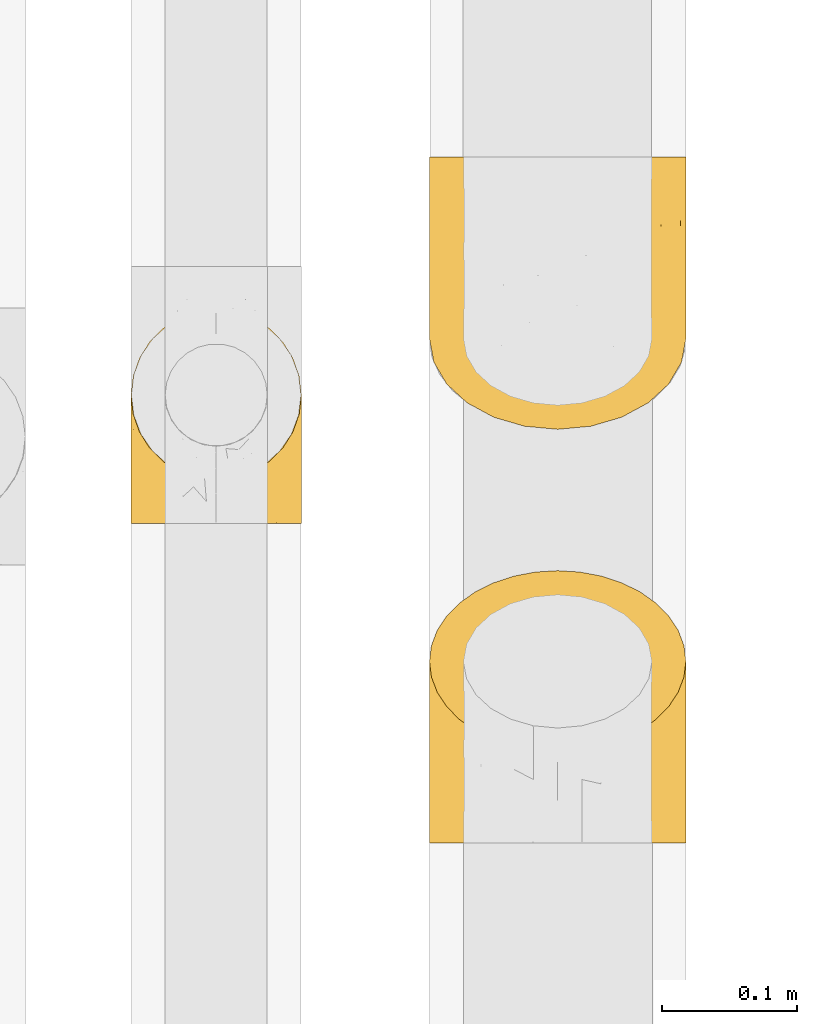
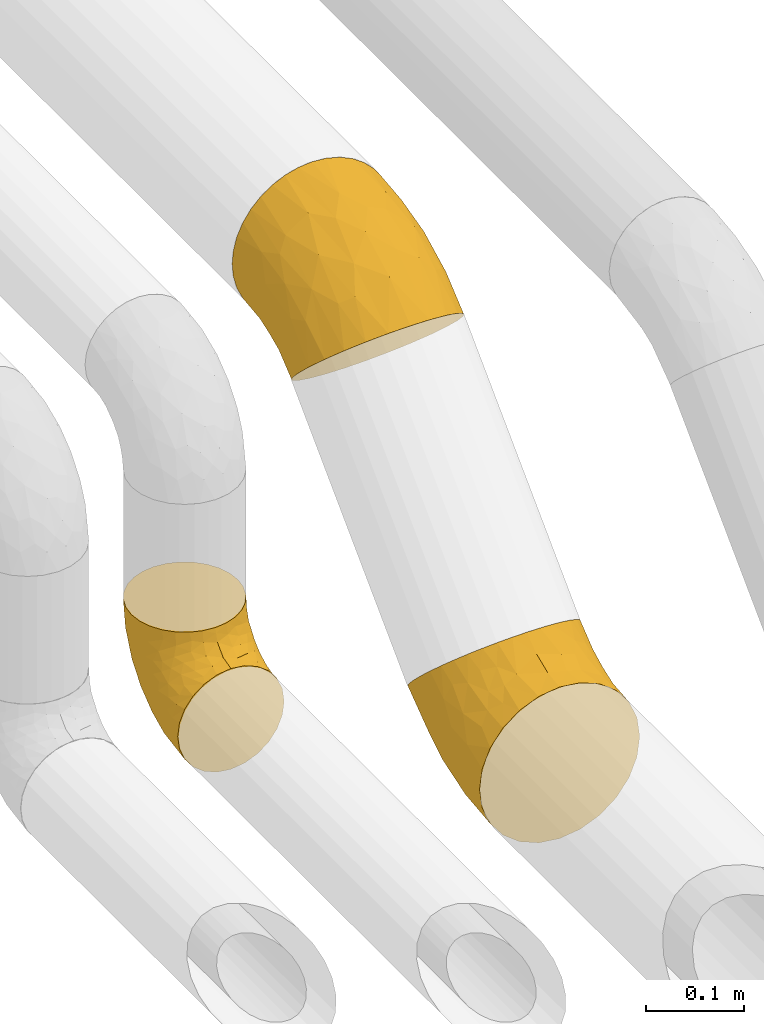
# One storey, part 103 of 827: 3 coverings.
"""IFC2X3 building model written with IfcOpenShell, lengths in millimetres."""

from ifc_helpers import new_model, entity, si_unit, converted_unit, derived_unit, direction, frame, origin, place, context, subcontext, project, spatial, faceted_brep, element, save


model = new_model("IFC2X3")

# Units and contexts
model_context = context("Model", 3, precision=0.01, world=origin(), true_north=direction((6.12303176911189e-17, 1.0)))
body_context = subcontext(model_context, "Body", "Model", "MODEL_VIEW")
ifc_project = project(units=[si_unit("LENGTHUNIT", "METRE", prefix="MILLI"), si_unit("AREAUNIT", "SQUARE_METRE"), si_unit("VOLUMEUNIT", "CUBIC_METRE"), converted_unit("PLANEANGLEUNIT", "DEGREE", entity("IfcRatioMeasure", 0.0174532925199433), si_unit("PLANEANGLEUNIT", "RADIAN"), dimensions=[0, 0, 0, 0, 0, 0, 0]), si_unit("MASSUNIT", "GRAM", prefix="KILO"), derived_unit("MASSDENSITYUNIT", [(si_unit("MASSUNIT", "GRAM", prefix="KILO"), 1), (si_unit("LENGTHUNIT", "METRE"), -3)]), derived_unit("MOMENTOFINERTIAUNIT", [(si_unit("LENGTHUNIT", "METRE"), 4)]), si_unit("TIMEUNIT", "SECOND"), si_unit("FREQUENCYUNIT", "HERTZ"), si_unit("THERMODYNAMICTEMPERATUREUNIT", "DEGREE_CELSIUS"), derived_unit("THERMALTRANSMITTANCEUNIT", [(si_unit("MASSUNIT", "GRAM", prefix="KILO"), 1), (si_unit("THERMODYNAMICTEMPERATUREUNIT", "KELVIN"), -1), (si_unit("TIMEUNIT", "SECOND"), -3)]), derived_unit("VOLUMETRICFLOWRATEUNIT", [(si_unit("LENGTHUNIT", "METRE"), 3), (si_unit("TIMEUNIT", "SECOND"), -1)]), derived_unit("MASSFLOWRATEUNIT", [(si_unit("MASSUNIT", "GRAM", prefix="KILO"), 1), (si_unit("TIMEUNIT", "SECOND"), -1)]), derived_unit("ROTATIONALFREQUENCYUNIT", [(si_unit("TIMEUNIT", "SECOND"), -1)]), si_unit("ELECTRICCURRENTUNIT", "AMPERE"), si_unit("ELECTRICVOLTAGEUNIT", "VOLT"), si_unit("POWERUNIT", "WATT"), si_unit("FORCEUNIT", "NEWTON", prefix="KILO"), si_unit("ILLUMINANCEUNIT", "LUX"), si_unit("LUMINOUSFLUXUNIT", "LUMEN"), si_unit("LUMINOUSINTENSITYUNIT", "CANDELA"), derived_unit("USERDEFINED", [(si_unit("MASSUNIT", "GRAM", prefix="KILO"), -1), (si_unit("LENGTHUNIT", "METRE"), -2), (si_unit("TIMEUNIT", "SECOND"), 3), (si_unit("LUMINOUSFLUXUNIT", "LUMEN"), 1)]), derived_unit("LINEARVELOCITYUNIT", [(si_unit("LENGTHUNIT", "METRE"), 1), (si_unit("TIMEUNIT", "SECOND"), -1)]), si_unit("PRESSUREUNIT", "PASCAL"), derived_unit("USERDEFINED", [(si_unit("LENGTHUNIT", "METRE"), -2), (si_unit("MASSUNIT", "GRAM", prefix="KILO"), 1), (si_unit("TIMEUNIT", "SECOND"), -2)]), derived_unit("LINEARFORCEUNIT", [(si_unit("MASSUNIT", "GRAM", prefix="KILO"), 1), (si_unit("LENGTHUNIT", "METRE"), 1), (si_unit("TIMEUNIT", "SECOND"), -2), (si_unit("LENGTHUNIT", "METRE"), -1)]), derived_unit("PLANARFORCEUNIT", [(si_unit("MASSUNIT", "GRAM", prefix="KILO"), 1), (si_unit("LENGTHUNIT", "METRE"), 1), (si_unit("TIMEUNIT", "SECOND"), -2), (si_unit("LENGTHUNIT", "METRE"), -2)])], contexts=[model_context])

# Site, building, storey
site_placement = place(None, origin())
site = spatial("IfcSite", under=ifc_project, at=site_placement, CompositionType="ELEMENT")
building_placement = place(site_placement, origin())
building = spatial("IfcBuilding", under=site, at=building_placement, CompositionType="ELEMENT")
storey_placement = place(building_placement, frame((0.0, 0.0, 28200.0)))
storey = spatial("IfcBuildingStorey", under=building, at=storey_placement, Name="08", CompositionType="ELEMENT", Elevation=28200.0)

# Coverings
covering_1_placement = place(storey_placement, frame((27023.89, 9323.51, 3003.55)))
element("IfcCovering", 1, at=covering_1_placement, inside=storey, Name=":ADSK_", ObjectType=":ADSK_", PredefinedType="INSULATION", context=body_context, shape_type="Brep", body=[
    faceted_brep([(128.89, 72.92, 215.12), (143.88, 77.86, 210.18), (157.42, 84.57, 203.47), (169.11, 92.84, 195.2), (178.59, 102.42, 185.62), (185.58, 113.01, 175.03), (189.86, 124.31, 163.73), (191.3, 135.95, 152.09), (189.85, 147.59, 140.45), (185.57, 158.89, 129.15), (178.58, 169.48, 118.56), (169.1, 179.06, 108.98), (157.41, 187.33, 100.71), (143.86, 194.03, 94.01), (128.88, 198.97, 89.07), (112.9, 202.0, 86.04), (96.45, 203.01, 85.03), (79.97, 202.0, 86.05), (64.0, 198.97, 89.07), (49.01, 194.03, 94.01), (35.47, 187.32, 100.72), (23.78, 179.05, 108.99), (14.3, 169.47, 118.57), (7.31, 158.88, 129.16), (3.03, 147.58, 140.46), (1.6, 135.95, 152.09), (3.04, 124.3, 163.74), (7.32, 113.0, 175.04), (14.31, 102.41, 185.63), (23.79, 92.83, 195.21), (35.48, 84.56, 203.48), (49.03, 77.86, 210.18), (64.02, 72.92, 215.12), (79.99, 69.89, 218.15), (96.45, 68.88, 219.16), (112.92, 69.9, 218.14), (71.9, 1.6, 188.06), (49.02, 1.6, 178.59), (29.38, 1.6, 163.51), (14.3, 1.6, 143.87), (4.83, 1.6, 120.99), (1.6, 1.6, 96.45), (4.83, 1.6, 71.9), (14.3, 1.6, 49.02), (29.38, 1.6, 29.38), (49.02, 1.6, 14.3), (71.9, 1.6, 4.83), (96.45, 1.6, 1.6), (120.99, 1.6, 4.83), (143.87, 1.6, 14.3), (163.51, 1.6, 29.38), (178.59, 1.6, 49.02), (188.06, 1.6, 71.9), (191.3, 1.6, 96.45), (188.06, 1.6, 120.99), (178.59, 1.6, 143.87), (163.51, 1.6, 163.51), (143.87, 1.6, 178.59), (120.99, 1.6, 188.06), (96.45, 1.6, 191.3), (148.44, 104.67, 37.62), (153.08, 49.39, 24.69), (137.11, 49.25, 14.9), (96.45, 57.17, 7.07), (123.57, 82.6, 17.49), (96.45, 110.6, 23.28), (96.45, 159.85, 49.6), (115.76, 135.24, 37.14), (166.75, 74.08, 43.35), (180.53, 91.1, 70.36), (181.55, 132.38, 94.96), (188.56, 99.69, 97.83), (186.72, 55.01, 73.95), (191.3, 38.66, 100.1), (180.27, 46.32, 56.37), (135.37, 150.71, 53.61), (162.08, 137.86, 66.8), (173.22, 121.84, 72.18), (191.3, 74.31, 110.91), (191.3, 107.15, 128.47), (186.39, 35.47, 130.17), (187.89, 65.55, 134.56), (179.11, 56.51, 153.88), (184.82, 86.32, 155.99), (174.14, 27.07, 153.27), (161.5, 25.9, 167.94), (168.52, 48.06, 166.8), (155.2, 45.81, 179.7), (140.11, 45.88, 190.36), (134.59, 24.1, 185.77), (123.18, 44.25, 197.11), (117.73, 23.39, 191.34), (166.26, 69.04, 180.25), (189.93, 89.08, 136.1), (189.1, 105.97, 152.6), (177.06, 75.48, 167.5), (150.17, 63.4, 193.25), (96.45, 49.17, 204.04), (96.45, 26.22, 194.54), (67.84, 39.7, 194.46), (54.37, 57.54, 197.6), (13.79, 56.5, 153.89), (8.08, 86.31, 156.0), (5.01, 65.54, 134.59), (2.97, 89.07, 136.11), (3.79, 105.96, 152.61), (52.05, 38.25, 186.79), (1.6, 38.66, 100.1), (6.5, 35.48, 130.17), (1.6, 74.31, 110.91), (18.75, 27.06, 153.26), (42.17, 23.58, 176.41), (28.93, 32.49, 167.0), (26.64, 69.03, 180.27), (39.77, 66.35, 192.69), (37.7, 45.81, 179.71), (16.37, 82.86, 173.47), (1.6, 107.15, 128.47), (4.39, 65.7, 83.48), (31.81, 101.99, 47.24), (35.92, 50.58, 28.01), (22.4, 52.35, 42.39), (73.84, 83.08, 16.35), (12.22, 48.87, 57.66), (5.54, 115.67, 101.77), (51.55, 67.49, 20.95), (12.22, 96.73, 73.07), (78.05, 135.48, 37.06), (58.02, 128.07, 40.32), (19.93, 135.83, 80.23), (41.41, 146.95, 62.18)], [[[0, 1, 2, 3, 4, 5, 6, 7, 8, 9, 10, 11, 12, 13, 14, 15, 16, 17, 18, 19, 20, 21, 22, 23, 24, 25, 26, 27, 28, 29, 30, 31, 32, 33, 34, 35]], [[36, 37, 38, 39, 40, 41, 42, 43, 44, 45, 46, 47, 48, 49, 50, 51, 52, 53, 54, 55, 56, 57, 58, 59]], [[60, 61, 62]], [[48, 47, 63]], [[64, 63, 65]], [[66, 67, 65]], [[51, 50, 68]], [[49, 61, 50]], [[69, 70, 71]], [[48, 63, 64]], [[72, 73, 52]], [[72, 74, 69]], [[60, 64, 75]], [[76, 77, 68]], [[72, 78, 73]], [[73, 53, 52]], [[72, 69, 71]], [[8, 71, 9]], [[60, 76, 68]], [[64, 65, 67]], [[67, 15, 14]], [[77, 10, 70]], [[76, 75, 12]], [[75, 13, 12]], [[68, 77, 69]], [[10, 77, 11]], [[14, 75, 67]], [[15, 66, 16]], [[68, 61, 60]], [[62, 61, 49]], [[48, 64, 62]], [[11, 77, 76]], [[79, 8, 7]], [[78, 71, 79]], [[61, 68, 50]], [[12, 11, 76]], [[71, 8, 79]], [[70, 10, 9]], [[15, 67, 66]], [[77, 70, 69]], [[60, 75, 76]], [[71, 70, 9]], [[64, 67, 75]], [[14, 13, 75]], [[48, 62, 49]], [[68, 69, 74]], [[60, 62, 64]], [[72, 71, 78]], [[74, 52, 51]], [[52, 74, 72]], [[68, 74, 51]], [[80, 78, 81]], [[54, 53, 73]], [[82, 81, 83]], [[80, 82, 84]], [[85, 86, 87]], [[55, 84, 56]], [[88, 89, 87]], [[54, 73, 80]], [[58, 57, 89]], [[90, 91, 89]], [[90, 0, 35]], [[2, 92, 3]], [[93, 78, 79]], [[59, 58, 91]], [[58, 89, 91]], [[78, 80, 73]], [[84, 85, 56]], [[94, 6, 5]], [[95, 4, 3]], [[86, 84, 82]], [[96, 2, 1]], [[95, 3, 92]], [[80, 84, 55]], [[93, 94, 83]], [[7, 6, 79]], [[86, 92, 87]], [[83, 95, 82]], [[85, 89, 57]], [[55, 54, 80]], [[34, 97, 35]], [[97, 90, 35]], [[93, 83, 81]], [[98, 90, 97]], [[0, 90, 88]], [[96, 1, 0]], [[85, 57, 56]], [[88, 90, 89]], [[82, 80, 81]], [[84, 86, 85]], [[83, 5, 4]], [[86, 82, 95]], [[85, 87, 89]], [[78, 93, 81]], [[94, 79, 6]], [[83, 94, 5]], [[79, 94, 93]], [[96, 88, 87]], [[88, 96, 0]], [[87, 92, 96]], [[2, 96, 92]], [[90, 98, 91]], [[59, 91, 98]], [[4, 95, 83]], [[86, 95, 92]], [[98, 99, 36]], [[100, 32, 31]], [[101, 102, 103]], [[104, 103, 102]], [[97, 99, 98]], [[59, 98, 36]], [[105, 27, 26]], [[99, 106, 36]], [[107, 40, 108]], [[109, 108, 103]], [[108, 39, 110]], [[41, 40, 107]], [[39, 108, 40]], [[106, 111, 37]], [[38, 111, 112]], [[39, 38, 110]], [[112, 113, 101]], [[31, 30, 114]], [[99, 97, 33]], [[38, 37, 111]], [[99, 33, 32]], [[102, 28, 27]], [[108, 109, 107]], [[113, 30, 29]], [[100, 114, 115]], [[30, 113, 114]], [[101, 110, 112]], [[32, 100, 99]], [[101, 113, 116]], [[102, 116, 28]], [[99, 100, 106]], [[108, 101, 103]], [[29, 28, 116]], [[106, 100, 115]], [[26, 25, 117]], [[104, 105, 117]], [[108, 110, 101]], [[104, 109, 103]], [[36, 106, 37]], [[33, 97, 34]], [[112, 111, 115]], [[111, 106, 115]], [[112, 115, 113]], [[38, 112, 110]], [[102, 27, 105]], [[109, 104, 117]], [[117, 105, 26]], [[102, 105, 104]], [[101, 116, 102]], [[29, 116, 113]], [[115, 114, 113]], [[31, 114, 100]], [[109, 118, 107]], [[119, 120, 121]], [[63, 122, 65]], [[123, 42, 118]], [[109, 117, 124]], [[41, 107, 42]], [[120, 119, 125]], [[126, 23, 22]], [[63, 47, 46]], [[42, 123, 43]], [[65, 127, 66]], [[122, 46, 125]], [[128, 127, 122]], [[44, 121, 120]], [[18, 17, 127]], [[125, 128, 122]], [[127, 128, 18]], [[121, 126, 119]], [[124, 117, 24]], [[45, 120, 125]], [[117, 25, 24]], [[43, 121, 44]], [[119, 128, 125]], [[118, 124, 126]], [[22, 129, 126]], [[124, 118, 109]], [[126, 124, 23]], [[129, 22, 21]], [[120, 45, 44]], [[21, 130, 129]], [[119, 130, 128]], [[128, 19, 18]], [[63, 46, 122]], [[65, 122, 127]], [[17, 16, 66]], [[130, 21, 20]], [[42, 107, 118]], [[127, 17, 66]], [[119, 126, 129]], [[19, 128, 130]], [[125, 46, 45]], [[24, 23, 124]], [[121, 43, 123]], [[123, 126, 121]], [[118, 126, 123]], [[129, 130, 119]], [[19, 130, 20]]]),
])
covering_2_placement = place(storey_placement, frame((27023.89, 9629.5, 3325.69)))
element("IfcCovering", 2, at=covering_2_placement, inside=storey, Name=":ADSK_", ObjectType=":ADSK_", PredefinedType="INSULATION", context=body_context, shape_type="Brep", body=[
    faceted_brep([(64.0, 203.01, 35.19), (49.01, 203.01, 42.18), (35.47, 203.01, 51.66), (23.78, 203.01, 63.35), (14.3, 203.01, 76.9), (7.31, 203.01, 91.88), (3.03, 203.01, 107.85), (1.6, 203.01, 124.31), (3.04, 203.01, 140.79), (7.32, 203.01, 156.76), (14.31, 203.01, 171.75), (23.79, 203.01, 185.29), (35.48, 203.01, 196.98), (49.03, 203.01, 206.46), (64.02, 203.01, 213.45), (79.99, 203.01, 217.73), (96.45, 203.01, 219.16), (112.92, 203.01, 217.72), (128.89, 203.01, 213.44), (143.88, 203.01, 206.45), (157.42, 203.01, 196.97), (169.11, 203.01, 185.28), (178.59, 203.01, 171.73), (185.58, 203.01, 156.74), (189.86, 203.01, 140.77), (191.3, 203.01, 124.31), (189.85, 203.01, 107.84), (185.57, 203.01, 91.87), (178.58, 203.01, 76.88), (169.1, 203.01, 63.34), (157.41, 203.01, 51.65), (143.86, 203.01, 42.17), (128.88, 203.01, 35.18), (112.9, 203.01, 30.9), (96.45, 203.01, 29.46), (79.97, 203.01, 30.91), (120.99, 133.45, 3.88), (143.87, 126.75, 10.58), (163.51, 116.09, 21.24), (178.59, 102.2, 35.13), (188.06, 86.02, 51.31), (191.3, 68.66, 68.66), (188.06, 51.31, 86.02), (178.59, 35.13, 102.2), (163.51, 21.24, 116.09), (143.87, 10.58, 126.75), (120.99, 3.88, 133.45), (96.45, 1.6, 135.73), (71.9, 3.88, 133.45), (49.02, 10.58, 126.75), (29.38, 21.24, 116.09), (14.3, 35.13, 102.2), (4.83, 51.31, 86.02), (1.6, 68.66, 68.66), (4.83, 86.02, 51.31), (14.3, 102.2, 35.13), (29.38, 116.09, 21.24), (49.02, 126.75, 10.58), (71.9, 133.45, 3.88), (96.45, 135.73, 1.6), (44.45, 99.95, 183.14), (39.81, 51.72, 153.2), (55.78, 44.71, 160.02), (96.45, 44.76, 171.16), (69.32, 70.11, 181.77), (96.45, 94.01, 197.48), (96.45, 147.44, 213.69), (77.13, 121.23, 205.1), (26.14, 82.38, 157.46), (12.36, 113.51, 150.4), (11.35, 160.09, 162.19), (4.33, 139.01, 137.05), (6.17, 90.53, 122.34), (1.6, 97.46, 92.29), (12.62, 71.96, 128.63), (57.52, 143.81, 204.4), (30.81, 144.05, 185.98), (19.67, 136.53, 170.85), (1.6, 130.3, 109.85), (1.6, 165.95, 120.66), (6.5, 116.46, 68.77), (5.0, 140.84, 86.93), (13.78, 148.1, 66.88), (8.07, 170.68, 86.47), (18.75, 126.85, 46.5), (31.39, 136.4, 35.3), (24.37, 151.27, 51.77), (37.69, 158.8, 41.06), (52.78, 166.39, 33.57), (58.3, 147.74, 21.41), (69.71, 170.01, 27.65), (75.16, 151.17, 16.97), (26.63, 175.62, 57.09), (2.96, 158.56, 102.48), (3.79, 182.17, 102.76), (15.83, 171.15, 70.66), (42.72, 180.81, 43.92), (96.45, 178.39, 26.22), (96.45, 155.44, 16.72), (125.05, 164.91, 26.3), (138.52, 179.75, 36.7), (179.1, 148.11, 66.87), (184.81, 170.68, 86.45), (187.88, 140.85, 86.91), (189.92, 158.57, 102.47), (189.1, 182.18, 102.74), (140.84, 158.47, 30.7), (191.3, 97.46, 92.29), (186.39, 116.47, 68.78), (191.3, 130.3, 109.85), (174.14, 126.85, 46.49), (150.72, 140.75, 27.67), (163.96, 140.4, 40.62), (166.25, 175.62, 57.08), (153.12, 182.51, 46.4), (155.19, 158.81, 41.05), (176.52, 180.59, 71.66), (191.3, 165.95, 120.66), (188.5, 104.83, 123.16), (161.08, 104.86, 174.45), (156.97, 54.91, 151.69), (170.49, 66.33, 142.78), (119.05, 69.65, 182.92), (180.67, 74.67, 129.52), (187.35, 153.09, 145.56), (141.34, 61.88, 168.64), (180.67, 119.41, 152.46), (114.84, 121.35, 205.33), (134.87, 118.4, 197.78), (172.96, 152.12, 175.05), (151.48, 147.22, 195.68)], [[[0, 1, 2, 3, 4, 5, 6, 7, 8, 9, 10, 11, 12, 13, 14, 15, 16, 17, 18, 19, 20, 21, 22, 23, 24, 25, 26, 27, 28, 29, 30, 31, 32, 33, 34, 35]], [[36, 37, 38, 39, 40, 41, 42, 43, 44, 45, 46, 47, 48, 49, 50, 51, 52, 53, 54, 55, 56, 57, 58, 59]], [[60, 61, 62]], [[48, 47, 63]], [[64, 63, 65]], [[66, 67, 65]], [[51, 50, 68]], [[49, 61, 50]], [[69, 70, 71]], [[48, 63, 64]], [[72, 73, 52]], [[72, 74, 69]], [[60, 64, 75]], [[76, 77, 68]], [[72, 78, 73]], [[73, 53, 52]], [[72, 69, 71]], [[8, 71, 9]], [[60, 76, 68]], [[64, 65, 67]], [[67, 15, 14]], [[77, 10, 70]], [[76, 75, 12]], [[75, 13, 12]], [[68, 77, 69]], [[10, 77, 11]], [[14, 75, 67]], [[15, 66, 16]], [[68, 61, 60]], [[62, 61, 49]], [[48, 64, 62]], [[11, 77, 76]], [[79, 8, 7]], [[78, 71, 79]], [[61, 68, 50]], [[12, 11, 76]], [[71, 8, 79]], [[70, 10, 9]], [[15, 67, 66]], [[77, 70, 69]], [[60, 75, 76]], [[71, 70, 9]], [[64, 67, 75]], [[14, 13, 75]], [[48, 62, 49]], [[68, 69, 74]], [[60, 62, 64]], [[72, 71, 78]], [[74, 52, 51]], [[52, 74, 72]], [[68, 74, 51]], [[80, 78, 81]], [[54, 53, 73]], [[82, 81, 83]], [[80, 82, 84]], [[85, 86, 87]], [[55, 84, 56]], [[88, 89, 87]], [[54, 73, 80]], [[58, 57, 89]], [[90, 91, 89]], [[90, 0, 35]], [[2, 92, 3]], [[93, 78, 79]], [[59, 58, 91]], [[58, 89, 91]], [[78, 80, 73]], [[84, 85, 56]], [[94, 6, 5]], [[95, 4, 3]], [[86, 84, 82]], [[96, 2, 1]], [[95, 3, 92]], [[80, 84, 55]], [[93, 94, 83]], [[7, 6, 79]], [[86, 92, 87]], [[83, 95, 82]], [[85, 89, 57]], [[55, 54, 80]], [[34, 97, 35]], [[97, 90, 35]], [[93, 83, 81]], [[98, 90, 97]], [[0, 90, 88]], [[96, 1, 0]], [[85, 57, 56]], [[88, 90, 89]], [[82, 80, 81]], [[84, 86, 85]], [[83, 5, 4]], [[86, 82, 95]], [[85, 87, 89]], [[78, 93, 81]], [[94, 79, 6]], [[83, 94, 5]], [[79, 94, 93]], [[96, 88, 87]], [[88, 96, 0]], [[87, 92, 96]], [[2, 96, 92]], [[90, 98, 91]], [[59, 91, 98]], [[4, 95, 83]], [[86, 95, 92]], [[98, 99, 36]], [[100, 32, 31]], [[101, 102, 103]], [[104, 103, 102]], [[97, 99, 98]], [[59, 98, 36]], [[105, 27, 26]], [[99, 106, 36]], [[107, 40, 108]], [[109, 108, 103]], [[108, 39, 110]], [[41, 40, 107]], [[39, 108, 40]], [[106, 111, 37]], [[38, 111, 112]], [[39, 38, 110]], [[112, 113, 101]], [[31, 30, 114]], [[99, 97, 33]], [[38, 37, 111]], [[99, 33, 32]], [[102, 28, 27]], [[108, 109, 107]], [[113, 30, 29]], [[100, 114, 115]], [[30, 113, 114]], [[101, 110, 112]], [[32, 100, 99]], [[101, 113, 116]], [[102, 116, 28]], [[99, 100, 106]], [[108, 101, 103]], [[29, 28, 116]], [[106, 100, 115]], [[26, 25, 117]], [[104, 105, 117]], [[108, 110, 101]], [[104, 109, 103]], [[36, 106, 37]], [[33, 97, 34]], [[112, 111, 115]], [[111, 106, 115]], [[112, 115, 113]], [[38, 112, 110]], [[102, 27, 105]], [[109, 104, 117]], [[117, 105, 26]], [[102, 105, 104]], [[101, 116, 102]], [[29, 116, 113]], [[115, 114, 113]], [[31, 114, 100]], [[109, 118, 107]], [[119, 120, 121]], [[63, 122, 65]], [[123, 42, 118]], [[109, 117, 124]], [[41, 107, 42]], [[120, 119, 125]], [[126, 23, 22]], [[63, 47, 46]], [[42, 123, 43]], [[65, 127, 66]], [[122, 46, 125]], [[128, 127, 122]], [[44, 121, 120]], [[18, 17, 127]], [[125, 128, 122]], [[127, 128, 18]], [[121, 126, 119]], [[124, 117, 24]], [[45, 120, 125]], [[117, 25, 24]], [[43, 121, 44]], [[119, 128, 125]], [[118, 124, 126]], [[22, 129, 126]], [[124, 118, 109]], [[126, 124, 23]], [[129, 22, 21]], [[120, 45, 44]], [[21, 130, 129]], [[119, 130, 128]], [[128, 19, 18]], [[63, 46, 122]], [[65, 122, 127]], [[17, 16, 66]], [[130, 21, 20]], [[42, 107, 118]], [[127, 17, 66]], [[119, 126, 129]], [[19, 128, 130]], [[125, 46, 45]], [[24, 23, 124]], [[121, 43, 123]], [[123, 126, 121]], [[118, 126, 123]], [[129, 130, 119]], [[19, 130, 20]]]),
])
covering_3_placement = place(storey_placement, frame((26802.99, 9559.97, 3035.35)))
element("IfcCovering", 3, at=covering_3_placement, inside=storey, Name=":ADSK_", ObjectType=":ADSK_", PredefinedType="INSULATION", context=body_context, shape_type="Brep", body=[
    faceted_brep([(126.11, 110.62, 159.65), (121.45, 123.95, 159.65), (113.94, 135.9, 159.65), (103.96, 145.89, 159.65), (92.0, 153.4, 159.65), (78.68, 158.06, 159.65), (64.65, 159.65, 159.65), (50.62, 158.06, 159.65), (37.29, 153.4, 159.65), (25.34, 145.89, 159.65), (15.35, 135.91, 159.65), (7.84, 123.95, 159.65), (3.18, 110.63, 159.65), (1.6, 96.6, 159.65), (3.18, 82.57, 159.65), (7.84, 69.24, 159.65), (15.35, 57.29, 159.65), (25.33, 47.3, 159.65), (37.29, 39.79, 159.65), (50.61, 35.13, 159.65), (64.65, 33.55, 159.65), (78.67, 35.13, 159.65), (92.0, 39.79, 159.65), (103.95, 47.3, 159.65), (113.94, 57.28, 159.65), (121.45, 69.24, 159.65), (126.11, 82.56, 159.65), (127.7, 96.6, 159.65), (64.65, 1.6, 127.7), (48.33, 1.6, 125.55), (33.12, 1.6, 119.25), (20.06, 1.6, 109.23), (10.04, 1.6, 96.17), (3.74, 1.6, 80.96), (3.01, 1.6, 75.35), (1.6, 1.6, 64.65), (3.74, 1.6, 48.33), (10.04, 1.6, 33.12), (20.06, 1.6, 20.06), (33.12, 1.6, 10.04), (48.33, 1.6, 3.74), (64.65, 1.6, 1.6), (80.96, 1.6, 3.74), (96.17, 1.6, 10.04), (109.23, 1.6, 20.06), (119.25, 1.6, 33.12), (125.55, 1.6, 48.33), (127.7, 1.6, 64.65), (126.29, 1.6, 75.35), (125.55, 1.6, 80.96), (119.25, 1.6, 96.17), (109.23, 1.6, 109.23), (96.17, 1.6, 119.25), (80.96, 1.6, 125.55), (101.1, 30.13, 16.01), (86.72, 39.4, 10.29), (98.7, 62.65, 24.76), (75.93, 28.52, 4.94), (64.65, 42.5, 6.98), (113.39, 115.57, 87.32), (111.06, 98.94, 62.3), (96.87, 111.29, 58.52), (84.07, 95.5, 36.35), (64.65, 80.62, 22.77), (64.65, 113.35, 47.89), (119.56, 43.71, 40.91), (112.75, 70.76, 42.82), (122.85, 62.71, 57.25), (125.08, 33.16, 51.19), (126.64, 53.41, 66.64), (105.78, 130.65, 98.56), (93.81, 137.68, 94.44), (96.07, 146.84, 123.53), (87.11, 66.58, 20.12), (75.77, 57.7, 12.95), (111.99, 39.88, 28.48), (64.65, 154.26, 118.74), (83.58, 152.07, 121.88), (80.96, 125.54, 65.08), (78.34, 142.81, 92.08), (122.85, 103.99, 98.53), (125.88, 79.4, 81.84), (120.97, 88.81, 72.43), (126.67, 104.86, 134.31), (122.64, 117.38, 129.11), (127.7, 57.43, 82.79), (127.7, 44.19, 76.04), (127.7, 30.95, 69.29), (107.12, 139.96, 129.58), (115.07, 127.03, 115.86), (102.81, 87.17, 42.36), (127.7, 78.45, 103.81), (127.7, 73.2, 98.55), (127.7, 67.94, 93.3), (127.7, 94.63, 147.25), (127.7, 93.29, 138.77), (127.7, 91.95, 130.29), (126.64, 94.6, 107.83), (127.7, 85.2, 117.05), (64.65, 138.47, 80.62), (127.7, 13.99, 66.61), (113.05, 40.46, 121.29), (101.81, 32.36, 128.09), (108.46, 28.71, 118.04), (126.21, 15.53, 79.47), (122.65, 29.06, 94.94), (126.55, 40.03, 86.01), (125.45, 45.36, 94.69), (126.01, 26.46, 83.06), (123.3, 47.56, 104.39), (118.99, 36.28, 107.01), (113.51, 55.57, 148.3), (104.6, 45.02, 143.82), (118.04, 57.55, 134.19), (101.6, 11.56, 116.87), (109.98, 19.2, 111.58), (92.1, 10.07, 122.36), (96.28, 21.04, 124.16), (121.05, 15.52, 94.28), (79.4, 13.84, 128.25), (79.19, 32.67, 146.72), (80.39, 24.86, 134.92), (93.14, 34.31, 138.87), (126.75, 81.47, 133.28), (125.71, 71.26, 121.77), (126.17, 81.64, 145.83), (64.65, 29.26, 143.67), (123.28, 70.65, 139.93), (64.65, 31.93, 153.63), (91.58, 27.99, 132.32), (107.1, 41.71, 132.59), (116.28, 50.14, 126.42), (116.32, 17.57, 102.97), (90.34, 37.62, 149.52), (122.74, 60.48, 120.88), (64.65, 17.57, 131.98), (126.77, 56.96, 96.12), (119.84, 48.98, 115.84), (124.71, 57.29, 108.2), (126.47, 68.25, 110.85), (37.19, 10.07, 122.36), (27.66, 16.58, 118.35), (49.9, 13.84, 128.25), (1.6, 13.99, 66.61), (50.1, 32.67, 146.72), (48.89, 24.86, 134.92), (2.88, 67.81, 110.73), (6.55, 61.09, 121.83), (3.58, 71.26, 121.77), (1.6, 57.43, 82.79), (1.6, 44.19, 76.04), (2.74, 40.03, 86.01), (11.25, 57.55, 134.19), (11.93, 51.01, 124.9), (21.09, 42.79, 132.35), (3.28, 26.46, 83.06), (6.64, 29.06, 94.94), (12.97, 17.57, 102.97), (19.31, 19.2, 111.58), (16.23, 40.46, 121.29), (21.44, 28.84, 118.82), (26.96, 33.48, 128.68), (8.24, 15.52, 94.28), (3.08, 15.53, 79.47), (10.3, 36.28, 107.01), (38.95, 37.62, 149.51), (33.01, 21.04, 124.16), (1.6, 94.63, 147.25), (1.6, 93.29, 138.77), (36.15, 34.31, 138.87), (24.69, 45.03, 143.82), (6.01, 70.65, 139.92), (2.54, 81.47, 133.28), (15.78, 55.58, 148.3), (1.6, 91.95, 130.29), (3.12, 81.64, 145.83), (37.33, 27.86, 131.94), (1.6, 78.45, 103.81), (1.6, 85.2, 117.05), (2.52, 56.96, 96.12), (3.84, 45.36, 94.69), (5.99, 47.57, 104.39), (9.35, 48.27, 114.83), (1.6, 67.94, 93.3), (4.58, 57.3, 108.2), (1.6, 30.95, 69.29), (30.59, 62.65, 24.76), (28.19, 30.13, 16.01), (17.3, 39.88, 28.48), (9.73, 43.71, 40.91), (42.57, 39.4, 10.29), (53.51, 55.79, 12.23), (53.42, 28.41, 4.91), (2.65, 53.41, 66.64), (2.62, 104.86, 134.31), (6.66, 117.39, 129.11), (6.44, 103.99, 98.53), (48.33, 125.54, 65.08), (32.42, 111.29, 58.52), (35.49, 137.69, 94.45), (2.65, 94.6, 107.83), (3.41, 79.4, 81.84), (4.21, 33.16, 51.19), (43.07, 68.78, 20.8), (23.52, 130.66, 98.56), (22.18, 139.97, 129.58), (33.1, 148.6, 131.93), (15.9, 115.58, 87.32), (14.23, 127.03, 115.86), (16.54, 70.76, 42.82), (45.22, 95.5, 36.35), (6.44, 62.71, 57.25), (8.33, 88.81, 72.43), (18.23, 98.94, 62.3), (32.99, 89.09, 38.39), (53.35, 78.72, 22.86), (48.76, 142.21, 92.06), (45.72, 152.07, 121.88)], [[[0, 1, 2, 3, 4, 5, 6, 7, 8, 9, 10, 11, 12, 13, 14, 15, 16, 17, 18, 19, 20, 21, 22, 23, 24, 25, 26, 27]], [[28, 29, 30, 31, 32, 33, 34, 35, 36, 37, 38, 39, 40, 41, 42, 43, 44, 45, 46, 47, 48, 49, 50, 51, 52, 53]], [[54, 55, 56]], [[57, 41, 58]], [[59, 60, 61]], [[62, 63, 64]], [[65, 66, 67]], [[68, 67, 69]], [[70, 71, 72]], [[55, 73, 56]], [[43, 42, 55]], [[55, 74, 73]], [[44, 75, 45]], [[44, 43, 54]], [[76, 5, 77]], [[71, 78, 79]], [[45, 75, 65]], [[46, 68, 47]], [[80, 81, 82]], [[0, 83, 84]], [[69, 85, 86, 87]], [[69, 81, 85]], [[84, 1, 0]], [[2, 88, 3]], [[4, 3, 72]], [[44, 54, 75]], [[5, 4, 77]], [[89, 2, 1]], [[72, 3, 88]], [[5, 76, 6]], [[70, 88, 89]], [[68, 65, 67]], [[88, 2, 89]], [[56, 90, 66]], [[64, 78, 62]], [[81, 91, 92, 93, 85]], [[83, 27, 94, 95, 96]], [[62, 61, 90]], [[97, 96, 98, 91]], [[80, 97, 81]], [[42, 57, 55]], [[62, 78, 61]], [[84, 89, 1]], [[78, 64, 99]], [[57, 74, 55]], [[76, 77, 79]], [[77, 72, 71]], [[82, 81, 67]], [[97, 83, 96]], [[80, 89, 84]], [[79, 78, 99]], [[71, 70, 61]], [[81, 97, 91]], [[83, 80, 84]], [[68, 87, 100, 47]], [[81, 69, 67]], [[68, 69, 87]], [[65, 46, 45]], [[65, 68, 46]], [[66, 65, 75]], [[56, 66, 75]], [[66, 60, 82]], [[71, 61, 78]], [[60, 66, 90]], [[83, 97, 80]], [[27, 83, 0]], [[59, 70, 89]], [[70, 59, 61]], [[89, 80, 59]], [[82, 59, 80]], [[55, 54, 43]], [[75, 54, 56]], [[66, 82, 67]], [[59, 82, 60]], [[41, 57, 42]], [[74, 57, 58]], [[58, 63, 74]], [[62, 74, 63]], [[74, 62, 73]], [[62, 56, 73]], [[4, 72, 77]], [[70, 72, 88]], [[76, 79, 99]], [[71, 79, 77]], [[62, 90, 56]], [[60, 90, 61]], [[101, 102, 103]], [[100, 87, 104]], [[105, 106, 107]], [[108, 104, 87]], [[107, 109, 110]], [[108, 87, 86]], [[111, 112, 113]], [[114, 51, 115]], [[116, 114, 117]], [[51, 50, 118]], [[119, 28, 53]], [[120, 121, 122]], [[98, 123, 124]], [[125, 96, 95]], [[116, 53, 52]], [[126, 121, 120]], [[104, 108, 118]], [[98, 124, 91]], [[25, 24, 127]], [[120, 128, 126]], [[122, 129, 102]], [[95, 94, 27, 26]], [[122, 102, 130]], [[125, 127, 123]], [[24, 111, 127]], [[21, 20, 128]], [[112, 130, 131]], [[48, 47, 100, 49]], [[132, 110, 115]], [[23, 111, 24]], [[129, 119, 117]], [[120, 133, 21]], [[112, 23, 22]], [[134, 113, 131]], [[121, 126, 135]], [[133, 112, 22]], [[128, 120, 21]], [[132, 51, 118]], [[120, 122, 133]], [[119, 121, 135]], [[129, 117, 102]], [[125, 26, 25]], [[26, 125, 95]], [[127, 125, 25]], [[28, 119, 135]], [[119, 53, 116]], [[127, 113, 124]], [[96, 125, 123]], [[112, 131, 113]], [[101, 103, 110]], [[85, 93, 136]], [[124, 123, 127]], [[98, 96, 123]], [[112, 111, 23]], [[127, 111, 113]], [[112, 133, 122]], [[21, 133, 22]], [[107, 110, 105]], [[110, 109, 137]], [[86, 106, 108]], [[138, 109, 136]], [[105, 118, 108]], [[107, 106, 85]], [[104, 50, 49]], [[124, 134, 139]], [[138, 93, 92]], [[92, 91, 139]], [[100, 104, 49]], [[118, 105, 132]], [[104, 118, 50]], [[110, 132, 105]], [[51, 132, 115]], [[108, 106, 105]], [[85, 106, 86]], [[114, 116, 52]], [[119, 116, 117]], [[51, 114, 52]], [[114, 115, 103]], [[117, 114, 103]], [[130, 102, 101]], [[117, 103, 102]], [[110, 103, 115]], [[130, 101, 131]], [[122, 130, 112]], [[101, 137, 131]], [[113, 134, 124]], [[137, 134, 131]], [[124, 139, 91]], [[134, 138, 139]], [[92, 139, 138]], [[110, 137, 101]], [[134, 137, 138]], [[136, 109, 107]], [[137, 109, 138]], [[85, 136, 107]], [[138, 136, 93]], [[122, 121, 129]], [[129, 121, 119]], [[30, 140, 141]], [[30, 29, 140]], [[28, 135, 142]], [[143, 35, 34, 33]], [[19, 144, 128]], [[126, 145, 135]], [[146, 147, 148]], [[149, 150, 151]], [[152, 153, 154]], [[155, 156, 151]], [[157, 31, 158]], [[159, 160, 161]], [[32, 162, 163]], [[158, 31, 30]], [[157, 164, 156]], [[126, 144, 145]], [[126, 128, 144]], [[18, 165, 19]], [[141, 166, 160]], [[14, 13, 167, 168]], [[163, 143, 33]], [[169, 165, 170]], [[18, 17, 170]], [[153, 159, 154]], [[142, 135, 145]], [[148, 171, 172]], [[159, 161, 154]], [[171, 152, 173]], [[173, 17, 16]], [[16, 15, 171]], [[158, 160, 164]], [[174, 175, 168]], [[173, 170, 17]], [[19, 128, 20]], [[174, 172, 175]], [[165, 169, 144]], [[162, 157, 156]], [[175, 172, 171]], [[144, 169, 145]], [[176, 169, 161]], [[166, 140, 142]], [[175, 171, 15]], [[168, 175, 14]], [[14, 175, 15]], [[142, 145, 176]], [[28, 142, 29]], [[148, 177, 146]], [[148, 178, 177]], [[152, 171, 148]], [[179, 180, 181]], [[164, 180, 156]], [[174, 178, 172]], [[148, 172, 178]], [[171, 173, 16]], [[170, 173, 152]], [[19, 165, 144]], [[170, 165, 18]], [[153, 182, 159]], [[146, 183, 184]], [[181, 180, 164]], [[180, 151, 156]], [[163, 155, 185]], [[155, 150, 185]], [[162, 156, 155]], [[143, 163, 185]], [[180, 179, 149]], [[32, 163, 33]], [[163, 162, 155]], [[31, 162, 32]], [[31, 157, 162]], [[164, 157, 158]], [[149, 151, 180]], [[155, 151, 150]], [[142, 140, 29]], [[141, 140, 166]], [[176, 145, 169]], [[30, 141, 158]], [[164, 160, 159]], [[158, 141, 160]], [[166, 161, 160]], [[154, 169, 170]], [[169, 154, 161]], [[152, 154, 170]], [[147, 152, 148]], [[153, 147, 182]], [[181, 182, 184]], [[164, 159, 182]], [[161, 166, 176]], [[142, 176, 166]], [[183, 146, 177]], [[184, 182, 147]], [[184, 147, 146]], [[152, 147, 153]], [[182, 181, 164]], [[179, 184, 183]], [[184, 179, 181]], [[149, 179, 183]], [[186, 187, 188]], [[37, 36, 189]], [[190, 191, 192]], [[193, 185, 150, 149]], [[194, 195, 196]], [[197, 198, 199]], [[200, 201, 177]], [[193, 202, 185]], [[203, 190, 186]], [[202, 189, 36]], [[41, 40, 192]], [[204, 205, 199]], [[9, 8, 206]], [[187, 190, 39]], [[40, 39, 190]], [[38, 37, 188]], [[207, 208, 204]], [[202, 35, 143, 185]], [[39, 38, 187]], [[195, 11, 208]], [[201, 149, 183, 177]], [[188, 189, 209]], [[197, 64, 210]], [[186, 188, 209]], [[13, 12, 194]], [[211, 201, 212]], [[12, 11, 195]], [[193, 201, 211]], [[212, 201, 196]], [[10, 208, 11]], [[213, 214, 209]], [[64, 63, 215]], [[216, 197, 199]], [[8, 217, 206]], [[7, 217, 8]], [[203, 191, 190]], [[7, 6, 76]], [[208, 205, 204]], [[205, 10, 9]], [[199, 205, 206]], [[7, 76, 217]], [[205, 208, 10]], [[216, 76, 99]], [[200, 177, 178, 174]], [[64, 197, 99]], [[63, 58, 191]], [[208, 196, 195]], [[196, 200, 194]], [[198, 197, 210]], [[216, 199, 217]], [[201, 193, 149]], [[202, 193, 211]], [[202, 211, 189]], [[35, 202, 36]], [[211, 212, 209]], [[37, 189, 188]], [[211, 209, 189]], [[213, 198, 214]], [[200, 174, 194]], [[201, 200, 196]], [[214, 198, 210]], [[213, 207, 198]], [[194, 174, 168, 167, 13]], [[195, 194, 12]], [[198, 204, 199]], [[204, 198, 207]], [[212, 207, 213]], [[196, 208, 207]], [[188, 187, 38]], [[190, 187, 186]], [[207, 212, 196]], [[209, 212, 213]], [[214, 203, 186]], [[191, 215, 63]], [[191, 203, 215]], [[192, 191, 58]], [[41, 192, 58]], [[190, 192, 40]], [[203, 210, 215]], [[64, 215, 210]], [[199, 206, 217]], [[9, 206, 205]], [[76, 216, 217]], [[99, 197, 216]], [[203, 214, 210]], [[209, 214, 186]]]),
])

save(model, "model.ifc")
